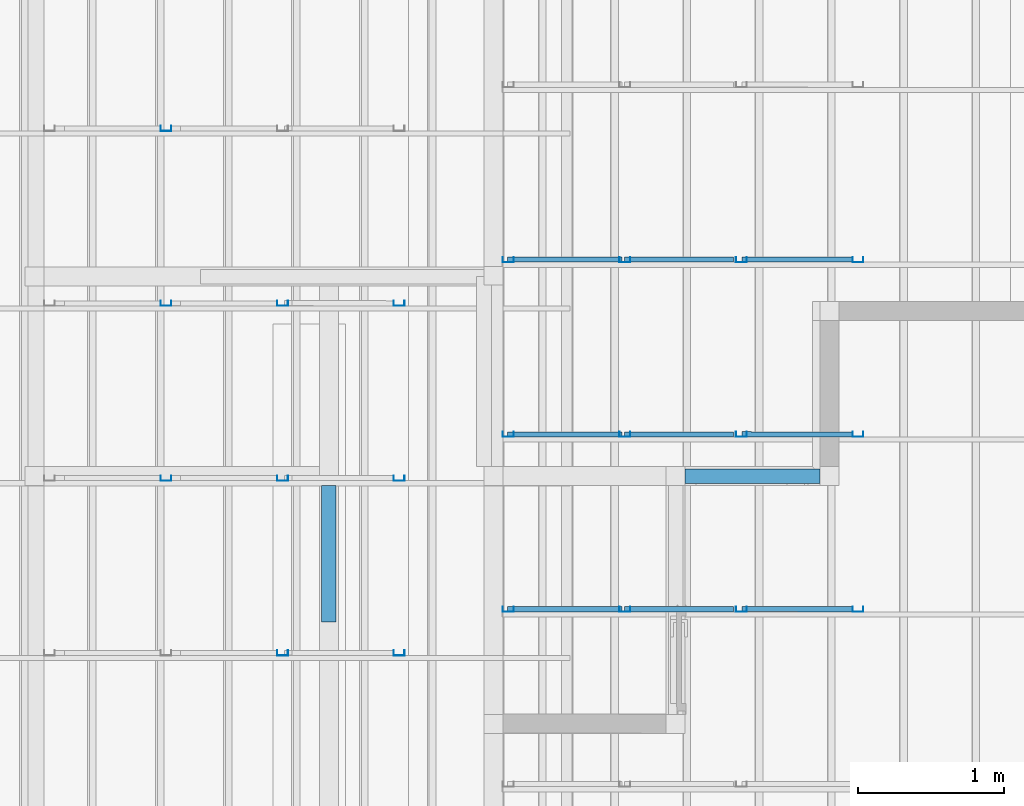
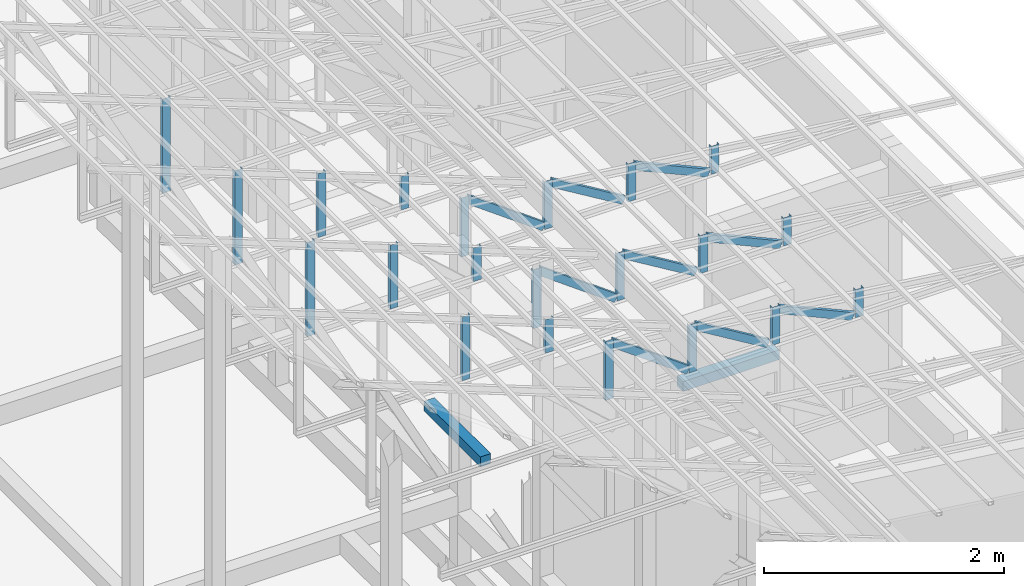
# One storey, part 17 of 22: 30 members, 2 beams, 2 elements without a shape of their own.
"""IFC4 building model written with IfcOpenShell, lengths in millimetres."""

import ifcopenshell
import ifcopenshell.guid

model = None  # the IFC model being written
_history = None  # IfcOwnerHistory: only IFC2X3 demands one
_inside = {}  # id of a spatial element -> (the spatial element, [elements in it])
_under = {}  # id of a project, library or spatial element -> (it, [spatial elements below it])
_declared = {}  # id of a project -> (the project, [libraries it declares])
_typed = {}  # id of a type object -> (the type object, [elements of that type])
_made_of = {}  # id of a material, layer set ... -> (it, [elements and type objects made of it])


def new_model(schema):
    """Start an empty IFC model of exactly this schema.

    Asked for "IFC4X3", IfcOpenShell would pick the latest addendum, in which some entities
    have other attributes; the version numbers below select the first issue.
    IFC2X3 requires an IfcOwnerHistory on every rooted entity: one is made here for all.
    """
    global model, _history
    if schema == "IFC4X3":
        model = ifcopenshell.file(schema_version=(4, 3, 0, 0))
    else:
        model = ifcopenshell.file(schema=schema)
    _inside.clear()
    _under.clear()
    _declared.clear()
    _typed.clear()
    _made_of.clear()
    _history = None
    if model.schema == "IFC2X3":
        org = make("IfcOrganization", Name="unknown")
        user = make(
            "IfcPersonAndOrganization",
            ThePerson=make("IfcPerson", FamilyName="unknown"),
            TheOrganization=org,
        )
        app = make(
            "IfcApplication",
            ApplicationDeveloper=org,
            Version="unknown",
            ApplicationFullName="unknown",
            ApplicationIdentifier="unknown",
        )
        _history = make(
            "IfcOwnerHistory",
            OwningUser=user,
            OwningApplication=app,
            ChangeAction="ADDED",
            CreationDate=0,
        )
    return model


def make(cls, **values):
    """One entity of the class cls with the attributes given. An attribute that is None is left unset."""
    return model.create_entity(
        cls, **{name: value for name, value in values.items() if value is not None}
    )


def entity(cls, *values):
    """Any entity or typed value of the class cls, its attributes in the order of the schema. None: left unset."""
    e = model.create_entity(cls)
    for i, value in enumerate(values):
        if value is not None:
            e[i] = value
    return e


def rooted(cls, **values):
    """An entity with a GlobalId (a new one), such as an element, a storey or a relation."""
    return make(cls, GlobalId=ifcopenshell.guid.new(), OwnerHistory=_history, **values)


def si_unit(unit_type, name, prefix=None):
    """IfcSIUnit, for example si_unit("LENGTHUNIT", "METRE", prefix="MILLI")."""
    return make("IfcSIUnit", UnitType=unit_type, Prefix=prefix, Name=name)


def converted_unit(unit_type, name, factor, base, dimensions=None, offset=None):
    """IfcConversionBasedUnit, such as the inch: factor (a typed value) times the base unit."""
    return make(
        "IfcConversionBasedUnit"
        if offset is None
        else "IfcConversionBasedUnitWithOffset",
        ConversionOffset=offset,
        Dimensions=None
        if dimensions is None
        else entity("IfcDimensionalExponents", *dimensions),
        UnitType=unit_type,
        Name=name,
        ConversionFactor=make(
            "IfcMeasureWithUnit", ValueComponent=factor, UnitComponent=base
        ),
    )


def assignment(units):
    """IfcUnitAssignment: the units of a project."""
    return None if units is None else make("IfcUnitAssignment", Units=units)


def point(xyz):
    """IfcCartesianPoint."""
    return None if xyz is None else make("IfcCartesianPoint", Coordinates=xyz)


def direction(xyz):
    """IfcDirection."""
    return None if xyz is None else make("IfcDirection", DirectionRatios=xyz)


def frame(location, z_axis=None, x_axis=None):
    """IfcAxis2Placement3D, a coordinate frame: its origin and axes. An axis left out is left unset."""
    return make(
        "IfcAxis2Placement3D",
        Location=point(location),
        Axis=direction(z_axis),
        RefDirection=direction(x_axis),
    )


def frame_2d(location, x_axis=None):
    """IfcAxis2Placement2D, a coordinate frame in the plane: its origin and x axis."""
    return make(
        "IfcAxis2Placement2D", Location=point(location), RefDirection=direction(x_axis)
    )


def origin_with_axes():
    """The frame at (0, 0, 0) with the z axis (0, 0, 1) and the x axis (1, 0, 0) written out."""
    return frame((0.0, 0.0, 0.0), z_axis=(0.0, 0.0, 1.0), x_axis=(1.0, 0.0, 0.0))


def origin_2d_with_axis():
    """The frame at (0, 0) in the plane with the x axis (1, 0) written out."""
    return frame_2d((0.0, 0.0), x_axis=(1.0, 0.0))


def place(relative_to, where):
    """IfcLocalPlacement: puts the frame where relative to a parent placement (None: the world)."""
    return make(
        "IfcLocalPlacement", PlacementRelTo=relative_to, RelativePlacement=where
    )


def context(
    kind, dimensions, precision=None, world=None, true_north=None, identifier=None
):
    """IfcGeometricRepresentationContext, for example the 3D "Model" context."""
    return make(
        "IfcGeometricRepresentationContext",
        ContextIdentifier=identifier,
        ContextType=kind,
        CoordinateSpaceDimension=dimensions,
        Precision=precision,
        WorldCoordinateSystem=world,
        TrueNorth=true_north,
    )


def subcontext(parent, identifier, kind, view, scale=None):
    """IfcGeometricRepresentationSubContext, for example "Body" below "Model"."""
    return make(
        "IfcGeometricRepresentationSubContext",
        ContextIdentifier=identifier,
        ContextType=kind,
        ParentContext=parent,
        TargetScale=scale,
        TargetView=view,
    )


def project(units=None, contexts=None):
    """IfcProject with its units and contexts."""
    return rooted(
        "IfcProject",
        Name="project",
        RepresentationContexts=contexts,
        UnitsInContext=assignment(units),
    )


def spatial(cls, under=None, at=None, **own):
    """A site, building, storey or space (cls), placed at a placement, below another one or the project."""
    s = rooted(cls, ObjectPlacement=at, **own)
    if under is not None:
        _under.setdefault(under.id(), (under, []))[1].append(s)
    return s


def profile(cls, at=None, kind="AREA", **sizes):
    """A parametric profile (cls). Its sizes go by their IFC names, for example OverallWidth=200.0."""
    return make(cls, ProfileType=kind, Position=at, **sizes)


def rectangle(**sizes):
    """IfcRectangleProfileDef."""
    return profile("IfcRectangleProfileDef", **sizes)


def c_section(**sizes):
    """IfcCShapeProfileDef."""
    return profile("IfcCShapeProfileDef", **sizes)


def extrude(swept, where, along, depth):
    """IfcExtrudedAreaSolid: the profile swept, set in the frame where, extruded along a direction by depth."""
    return make(
        "IfcExtrudedAreaSolid",
        SweptArea=swept,
        Position=where,
        ExtrudedDirection=direction(along),
        Depth=depth,
    )


def shape(context_of_items, identifier, shape_type, items):
    """IfcShapeRepresentation: the items that make up one representation, for example the "Body"."""
    return make(
        "IfcShapeRepresentation",
        ContextOfItems=context_of_items,
        RepresentationIdentifier=identifier,
        RepresentationType=shape_type,
        Items=items,
    )


def material(Name=None, Category=None):
    """IfcMaterial."""
    return make("IfcMaterial", Name=Name, Category=Category)


def material_profile(
    of_material, cross_section, Name=None, Category=None, Priority=None
):
    """IfcMaterialProfile: a cross section and its material."""
    return make(
        "IfcMaterialProfile",
        Name=Name,
        Material=of_material,
        Profile=cross_section,
        Priority=Priority,
        Category=Category,
    )


def profile_set(profiles, Name=None, composite=None):
    """IfcMaterialProfileSet."""
    return make(
        "IfcMaterialProfileSet",
        Name=Name,
        MaterialProfiles=profiles,
        CompositeProfile=composite,
    )


def profile_usage(for_profile_set, cardinal=None, extent=None):
    """IfcMaterialProfileSetUsage: how a profile set lies along its element."""
    return make(
        "IfcMaterialProfileSetUsage",
        ForProfileSet=for_profile_set,
        CardinalPoint=cardinal,
        ReferenceExtent=extent,
    )


def made_of(thing, what):
    """Note that an element or type object is made of a material, layer set ...; save() writes the relation."""
    if what is not None:
        _made_of.setdefault(what.id(), (what, []))[1].append(thing)
    return thing


def type_object(cls, material=None, **own):
    """A type object (cls), such as IfcWallType, which elements share."""
    return made_of(rooted(cls, **own), material)


def element(
    cls,
    number,
    at=None,
    inside=None,
    cuts=None,
    type_object=None,
    material=None,
    context=None,
    identifier="Body",
    shape_type=None,
    held_by="IfcProductDefinitionShape",
    body=None,
    shapes=None,
    **own,
):
    """One element of the class cls, such as IfcWall. Its Tag is "e" and its number.

    at: its placement. inside: the storey or other place that contains it. cuts: it is an
    opening in that element (IfcRelVoidsElement). A single representation is given by context,
    identifier, shape_type and body (its items); several are given by shapes. held_by: the class
    of the entity that holds the representations. save() writes the other relations.
    """
    e = rooted(cls, Tag="e%d" % number, ObjectPlacement=at, **own)
    if body is not None:
        shapes = [shape(context, identifier, shape_type, body)]
    if shapes is not None:
        e.Representation = make(held_by, Representations=shapes)
    if inside is not None:
        _inside.setdefault(inside.id(), (inside, []))[1].append(e)
    if cuts is not None:
        rooted(
            "IfcRelVoidsElement", RelatingBuildingElement=cuts, RelatedOpeningElement=e
        )
    if type_object is not None:
        _typed.setdefault(type_object.id(), (type_object, []))[1].append(e)
    return made_of(e, material)


def aggregate(whole, parts):
    """IfcRelAggregates: a whole, such as a stair, and the parts it consists of."""
    return rooted("IfcRelAggregates", RelatingObject=whole, RelatedObjects=parts)


def save(model, path):
    """Write the relations noted so far, then the file.

    IfcRelAggregates (storeys below a building ...), IfcRelContainedInSpatialStructure (elements
    in a storey), IfcRelDefinesByType, IfcRelAssociatesMaterial and IfcRelDeclares: one each for
    every whole, place, type object, material and project.
    """
    for whole, parts in _under.values():
        aggregate(whole, parts)
    for where, things in _inside.values():
        rooted(
            "IfcRelContainedInSpatialStructure",
            RelatedElements=things,
            RelatingStructure=where,
        )
    for kind, things in _typed.values():
        rooted("IfcRelDefinesByType", RelatedObjects=things, RelatingType=kind)
    for what, things in _made_of.values():
        rooted("IfcRelAssociatesMaterial", RelatedObjects=things, RelatingMaterial=what)
    for by, libraries in _declared.values():
        rooted("IfcRelDeclares", RelatingContext=by, RelatedDefinitions=libraries)
    model.write(path)


model = new_model("IFC4")

# Units and contexts
model_context = context("Model", 3, precision=1e-05, world=origin_with_axes())
plan_context = context("Plan", 2, precision=1e-05, world=origin_2d_with_axis())
body_context = subcontext(model_context, "Body", "Model", "MODEL_VIEW")
ifc_project = project(units=[si_unit("VOLUMEUNIT", "CUBIC_METRE"), si_unit("LENGTHUNIT", "METRE", prefix="MILLI"), si_unit("AREAUNIT", "SQUARE_METRE"), converted_unit("PLANEANGLEUNIT", "degree", entity("IfcReal", 0.0174532925199433), si_unit("PLANEANGLEUNIT", "RADIAN"), dimensions=[0, 0, 0, 0, 0, 0, 0])], contexts=[model_context, plan_context])

# Site, building, storey
site_placement = place(None, origin_with_axes())
site = spatial("IfcSite", under=ifc_project, at=site_placement)
building_placement = place(site_placement, origin_with_axes())
building = spatial("IfcBuilding", under=site, at=building_placement, Name="2")
storey_placement = place(building_placement, frame((0.0, 0.0, 200.000002980232), z_axis=(0.0, 0.0, 1.0), x_axis=(1.0, 0.0, 0.0)))
storey = spatial("IfcBuildingStorey", under=building, at=storey_placement)

# Assembly, members
assembly_1_placement = place(storey_placement, frame((-1561.45393848419, 6600.0657081604, 3019.63977515697), z_axis=(0.0, 0.0, 1.0), x_axis=(1.0, 0.0, 0.0)))
assembly_1 = element("IfcElementAssembly", 1, at=assembly_1_placement, inside=storey, Name="K1")
ifc_material_1 = material(Name="STEEL")
ifc_material_profile_1 = material_profile(ifc_material_1, c_section(Depth=75.0, Width=35.0, WallThickness=1.0, Girth=1.0, kind="CURVE"))
ifc_profile_set_1 = profile_set([ifc_material_profile_1])
ifc_profile_usage_1 = profile_usage(ifc_profile_set_1, cardinal=9)
member_type = type_object("IfcMemberType", Name="C75", PredefinedType="CHORD", material=ifc_profile_set_1)
member_1_placement = place(assembly_1_placement, frame((100.488781929016, 2398.93293380737, 276.402950286865), z_axis=(-8.7422719730052e-08, 3.25841369885875e-07, -0.999999999999943), x_axis=(1.62920684942936e-07, 0.999999999999934, 3.25841369885871e-07)))
member_1 = element("IfcMember", 2, at=member_1_placement, type_object=member_type, material=ifc_profile_usage_1, Name="Member", context=body_context, shape_type="SweptSolid", body=[
    extrude(c_section(Depth=75.0, Width=35.0, WallThickness=1.0, Girth=1.0, kind="CURVE"), frame((17.5, -37.5, 0.0), z_axis=(0.0, 0.0, 1.0), x_axis=(1.0, 0.0, 0.0)), (0.0, 0.0, 1.0), 285.419225275215),
])
ifc_profile_usage_2 = profile_usage(ifc_profile_set_1, cardinal=9)
member_2_placement = place(assembly_1_placement, frame((-1499.51112270355, 2398.93293380737, 479.381561279297), z_axis=(0.855801528545197, -4.23314648434558e-08, -0.517304304775924), x_axis=(7.5497901264043e-08, 0.999999999999996, 4.30689546249139e-08)))
member_2 = element("IfcMember", 3, at=member_2_placement, type_object=member_type, material=ifc_profile_usage_2, Name="Member", context=body_context, shape_type="SweptSolid", body=[
    extrude(c_section(Depth=75.0, Width=35.0, WallThickness=1.0, Girth=1.0, kind="CURVE"), frame((17.5, -37.5, 0.0), z_axis=(0.0, 0.0, 1.0), x_axis=(1.0, 0.0, 0.0)), (0.0, 0.0, 1.0), 826.976096113964),
])
ifc_profile_usage_3 = profile_usage(ifc_profile_set_1, cardinal=9)
member_3_placement = place(assembly_1_placement, frame((-1499.51112270355, 2398.93293380737, 479.381561279297), z_axis=(-8.7422719730052e-08, 3.25841369885875e-07, -0.999999999999943), x_axis=(1.62920684942936e-07, 0.999999999999934, 3.25841369885871e-07)))
member_3 = element("IfcMember", 4, at=member_3_placement, type_object=member_type, material=ifc_profile_usage_3, Name="Member", context=body_context, shape_type="SweptSolid", body=[
    extrude(c_section(Depth=75.0, Width=35.0, WallThickness=1.0, Girth=1.0, kind="CURVE"), frame((17.5, -37.5, 0.0), z_axis=(0.0, 0.0, 1.0), x_axis=(1.0, 0.0, 0.0)), (0.0, 0.0, 1.0), 488.397843745656),
])
ifc_profile_usage_4 = profile_usage(ifc_profile_set_1, cardinal=9)
member_4_placement = place(assembly_1_placement, frame((-2299.51107501984, 2398.93293380737, 592.46301651001), z_axis=(0.807471586940316, -1.26964538798404e-07, -0.589906464012789), x_axis=(7.54979012640426e-08, 0.999999999999991, -1.1188575399501e-07)))
member_4 = element("IfcMember", 5, at=member_4_placement, type_object=member_type, material=ifc_profile_usage_4, Name="Member", context=body_context, shape_type="SweptSolid", body=[
    extrude(c_section(Depth=75.0, Width=35.0, WallThickness=1.0, Girth=1.0, kind="CURVE"), frame((17.5, -37.5, 0.0), z_axis=(0.0, 0.0, 1.0), x_axis=(1.0, 0.0, 0.0)), (0.0, 0.0, 1.0), 921.685377112707),
])
ifc_profile_usage_5 = profile_usage(ifc_profile_set_1, cardinal=9)
member_5_placement = place(assembly_1_placement, frame((-702.355027198792, 2399.93238449097, 368.052959442139), z_axis=(0.912206913056706, -0.00121979383816088, -0.409728031594797), x_axis=(0.00137145876901944, 0.999999056639273, 7.62981516029096e-05)))
member_5 = element("IfcMember", 6, at=member_5_placement, type_object=member_type, material=ifc_profile_usage_5, Name="Member", context=body_context, shape_type="SweptSolid", body=[
    extrude(c_section(Depth=75.0, Width=35.0, WallThickness=1.0, Girth=1.0, kind="CURVE"), frame((17.5, -37.5, 0.0), z_axis=(0.0, 0.0, 1.0), x_axis=(1.0, 0.0, 0.0)), (0.0, 0.0, 1.0), 791.494517196627),
])
ifc_profile_usage_6 = profile_usage(ifc_profile_set_1, cardinal=9)
member_6_placement = place(assembly_1_placement, frame((-2299.51107501984, 2398.93293380737, 592.46301651001), z_axis=(-8.7422719730052e-08, 3.25841369885875e-07, -0.999999999999943), x_axis=(1.62920684942936e-07, 0.999999999999934, 3.25841369885871e-07)))
member_6 = element("IfcMember", 7, at=member_6_placement, type_object=member_type, material=ifc_profile_usage_6, Name="Member", context=body_context, shape_type="SweptSolid", body=[
    extrude(c_section(Depth=75.0, Width=35.0, WallThickness=1.0, Girth=1.0, kind="CURVE"), frame((17.5, -37.5, 0.0), z_axis=(0.0, 0.0, 1.0), x_axis=(1.0, 0.0, 0.0)), (0.0, 0.0, 1.0), 601.479041515268),
])
ifc_profile_usage_7 = profile_usage(ifc_profile_set_1, cardinal=9)
member_7_placement = place(assembly_1_placement, frame((-699.511170387268, 2398.93293380737, 377.824306488037), z_axis=(-8.7422719730052e-08, 3.25841369885875e-07, -0.999999999999943), x_axis=(1.62920684942936e-07, 0.999999999999934, 3.25841369885871e-07)))
member_7 = element("IfcMember", 8, at=member_7_placement, type_object=member_type, material=ifc_profile_usage_7, Name="Member", context=body_context, shape_type="SweptSolid", body=[
    extrude(c_section(Depth=75.0, Width=35.0, WallThickness=1.0, Girth=1.0, kind="CURVE"), frame((17.5, -37.5, 0.0), z_axis=(0.0, 0.0, 1.0), x_axis=(1.0, 0.0, 0.0)), (0.0, 0.0, 1.0), 386.840589191612),
])
ifc_profile_usage_8 = profile_usage(ifc_profile_set_1, cardinal=9)
member_8_placement = place(assembly_1_placement, frame((-1499.51112270355, 3598.93274307251, 479.381561279297), z_axis=(0.855801528545197, -4.23314648434558e-08, -0.517304304775924), x_axis=(7.5497901264043e-08, 0.999999999999996, 4.30689546249139e-08)))
member_8 = element("IfcMember", 9, at=member_8_placement, type_object=member_type, material=ifc_profile_usage_8, Name="Member", context=body_context, shape_type="SweptSolid", body=[
    extrude(c_section(Depth=75.0, Width=35.0, WallThickness=1.0, Girth=1.0, kind="CURVE"), frame((17.5, -37.5, 0.0), z_axis=(0.0, 0.0, 1.0), x_axis=(1.0, 0.0, 0.0)), (0.0, 0.0, 1.0), 826.976096113964),
])
ifc_profile_usage_9 = profile_usage(ifc_profile_set_1, cardinal=9)
member_9_placement = place(assembly_1_placement, frame((-1499.51112270355, 3598.93274307251, 479.381561279297), z_axis=(-8.7422719730052e-08, 3.25841369885875e-07, -0.999999999999943), x_axis=(1.62920684942936e-07, 0.999999999999934, 3.25841369885871e-07)))
member_9 = element("IfcMember", 10, at=member_9_placement, type_object=member_type, material=ifc_profile_usage_9, Name="Member", context=body_context, shape_type="SweptSolid", body=[
    extrude(c_section(Depth=75.0, Width=35.0, WallThickness=1.0, Girth=1.0, kind="CURVE"), frame((17.5, -37.5, 0.0), z_axis=(0.0, 0.0, 1.0), x_axis=(1.0, 0.0, 0.0)), (0.0, 0.0, 1.0), 488.397843745656),
])
ifc_profile_usage_10 = profile_usage(ifc_profile_set_1, cardinal=9)
member_10_placement = place(assembly_1_placement, frame((-702.355027198792, 3599.9321937561, 368.052959442139), z_axis=(0.912206913056706, -0.00121979383816088, -0.409728031594797), x_axis=(0.00137145876901944, 0.999999056639273, 7.62981516029096e-05)))
member_10 = element("IfcMember", 11, at=member_10_placement, type_object=member_type, material=ifc_profile_usage_10, Name="Member", context=body_context, shape_type="SweptSolid", body=[
    extrude(c_section(Depth=75.0, Width=35.0, WallThickness=1.0, Girth=1.0, kind="CURVE"), frame((17.5, -37.5, 0.0), z_axis=(0.0, 0.0, 1.0), x_axis=(1.0, 0.0, 0.0)), (0.0, 0.0, 1.0), 791.494517196627),
])
ifc_profile_usage_11 = profile_usage(ifc_profile_set_1, cardinal=9)
member_11_placement = place(assembly_1_placement, frame((100.488781929016, 3598.93274307251, 276.402950286865), z_axis=(-8.7422719730052e-08, 3.25841369885875e-07, -0.999999999999943), x_axis=(1.62920684942936e-07, 0.999999999999934, 3.25841369885871e-07)))
member_11 = element("IfcMember", 12, at=member_11_placement, type_object=member_type, material=ifc_profile_usage_11, Name="Member", context=body_context, shape_type="SweptSolid", body=[
    extrude(c_section(Depth=75.0, Width=35.0, WallThickness=1.0, Girth=1.0, kind="CURVE"), frame((17.5, -37.5, 0.0), z_axis=(0.0, 0.0, 1.0), x_axis=(1.0, 0.0, 0.0)), (0.0, 0.0, 1.0), 285.419225275215),
])
ifc_profile_usage_12 = profile_usage(ifc_profile_set_1, cardinal=9)
member_12_placement = place(assembly_1_placement, frame((-2299.51107501984, 3598.93274307251, 592.46301651001), z_axis=(0.807471586940316, -1.26964538798404e-07, -0.589906464012789), x_axis=(7.54979012640426e-08, 0.999999999999991, -1.1188575399501e-07)))
member_12 = element("IfcMember", 13, at=member_12_placement, type_object=member_type, material=ifc_profile_usage_12, Name="Member", context=body_context, shape_type="SweptSolid", body=[
    extrude(c_section(Depth=75.0, Width=35.0, WallThickness=1.0, Girth=1.0, kind="CURVE"), frame((17.5, -37.5, 0.0), z_axis=(0.0, 0.0, 1.0), x_axis=(1.0, 0.0, 0.0)), (0.0, 0.0, 1.0), 921.685377112707),
])
ifc_profile_usage_13 = profile_usage(ifc_profile_set_1, cardinal=9)
member_13_placement = place(assembly_1_placement, frame((-2299.51107501984, 3598.93274307251, 592.46301651001), z_axis=(-8.7422719730052e-08, 3.25841369885875e-07, -0.999999999999943), x_axis=(1.62920684942936e-07, 0.999999999999934, 3.25841369885871e-07)))
member_13 = element("IfcMember", 14, at=member_13_placement, type_object=member_type, material=ifc_profile_usage_13, Name="Member", context=body_context, shape_type="SweptSolid", body=[
    extrude(c_section(Depth=75.0, Width=35.0, WallThickness=1.0, Girth=1.0, kind="CURVE"), frame((17.5, -37.5, 0.0), z_axis=(0.0, 0.0, 1.0), x_axis=(1.0, 0.0, 0.0)), (0.0, 0.0, 1.0), 601.479041515268),
])
ifc_profile_usage_14 = profile_usage(ifc_profile_set_1, cardinal=9)
member_14_placement = place(assembly_1_placement, frame((-699.511170387268, 3598.93274307251, 377.824306488037), z_axis=(-8.7422719730052e-08, 3.25841369885875e-07, -0.999999999999943), x_axis=(1.62920684942936e-07, 0.999999999999934, 3.25841369885871e-07)))
member_14 = element("IfcMember", 15, at=member_14_placement, type_object=member_type, material=ifc_profile_usage_14, Name="Member", context=body_context, shape_type="SweptSolid", body=[
    extrude(c_section(Depth=75.0, Width=35.0, WallThickness=1.0, Girth=1.0, kind="CURVE"), frame((17.5, -37.5, 0.0), z_axis=(0.0, 0.0, 1.0), x_axis=(1.0, 0.0, 0.0)), (0.0, 0.0, 1.0), 386.840589191612),
])
ifc_profile_usage_15 = profile_usage(ifc_profile_set_1, cardinal=9)
member_15_placement = place(assembly_1_placement, frame((-702.355027198792, 4799.93200302124, 368.052959442139), z_axis=(0.912206913056706, -0.00121979383816088, -0.409728031594797), x_axis=(0.00137145876901944, 0.999999056639273, 7.62981516029096e-05)))
member_15 = element("IfcMember", 16, at=member_15_placement, type_object=member_type, material=ifc_profile_usage_15, Name="Member", context=body_context, shape_type="SweptSolid", body=[
    extrude(c_section(Depth=75.0, Width=35.0, WallThickness=1.0, Girth=1.0, kind="CURVE"), frame((17.5, -37.5, 0.0), z_axis=(0.0, 0.0, 1.0), x_axis=(1.0, 0.0, 0.0)), (0.0, 0.0, 1.0), 791.494517196627),
])
ifc_profile_usage_16 = profile_usage(ifc_profile_set_1, cardinal=9)
member_16_placement = place(assembly_1_placement, frame((-1499.51112270355, 4798.93255233765, 479.381561279297), z_axis=(-8.7422719730052e-08, 3.25841369885875e-07, -0.999999999999943), x_axis=(1.62920684942936e-07, 0.999999999999934, 3.25841369885871e-07)))
member_16 = element("IfcMember", 17, at=member_16_placement, type_object=member_type, material=ifc_profile_usage_16, Name="Member", context=body_context, shape_type="SweptSolid", body=[
    extrude(c_section(Depth=75.0, Width=35.0, WallThickness=1.0, Girth=1.0, kind="CURVE"), frame((17.5, -37.5, 0.0), z_axis=(0.0, 0.0, 1.0), x_axis=(1.0, 0.0, 0.0)), (0.0, 0.0, 1.0), 488.397843745656),
])
ifc_profile_usage_17 = profile_usage(ifc_profile_set_1, cardinal=9)
member_17_placement = place(assembly_1_placement, frame((-2299.51107501984, 4798.93255233765, 592.46301651001), z_axis=(0.807471586940316, -1.26964538798404e-07, -0.589906464012789), x_axis=(7.54979012640426e-08, 0.999999999999991, -1.1188575399501e-07)))
member_17 = element("IfcMember", 18, at=member_17_placement, type_object=member_type, material=ifc_profile_usage_17, Name="Member", context=body_context, shape_type="SweptSolid", body=[
    extrude(c_section(Depth=75.0, Width=35.0, WallThickness=1.0, Girth=1.0, kind="CURVE"), frame((17.5, -37.5, 0.0), z_axis=(0.0, 0.0, 1.0), x_axis=(1.0, 0.0, 0.0)), (0.0, 0.0, 1.0), 921.685377112707),
])
ifc_profile_usage_18 = profile_usage(ifc_profile_set_1, cardinal=9)
member_18_placement = place(assembly_1_placement, frame((-2299.51107501984, 4798.93255233765, 592.46301651001), z_axis=(-8.7422719730052e-08, 3.25841369885875e-07, -0.999999999999943), x_axis=(1.62920684942936e-07, 0.999999999999934, 3.25841369885871e-07)))
member_18 = element("IfcMember", 19, at=member_18_placement, type_object=member_type, material=ifc_profile_usage_18, Name="Member", context=body_context, shape_type="SweptSolid", body=[
    extrude(c_section(Depth=75.0, Width=35.0, WallThickness=1.0, Girth=1.0, kind="CURVE"), frame((17.5, -37.5, 0.0), z_axis=(0.0, 0.0, 1.0), x_axis=(1.0, 0.0, 0.0)), (0.0, 0.0, 1.0), 601.479041515268),
])
ifc_profile_usage_19 = profile_usage(ifc_profile_set_1, cardinal=9)
member_19_placement = place(assembly_1_placement, frame((-1499.51112270355, 4798.93255233765, 479.381561279297), z_axis=(0.855801528545197, -4.23314648434558e-08, -0.517304304775924), x_axis=(7.5497901264043e-08, 0.999999999999996, 4.30689546249139e-08)))
member_19 = element("IfcMember", 20, at=member_19_placement, type_object=member_type, material=ifc_profile_usage_19, Name="Member", context=body_context, shape_type="SweptSolid", body=[
    extrude(c_section(Depth=75.0, Width=35.0, WallThickness=1.0, Girth=1.0, kind="CURVE"), frame((17.5, -37.5, 0.0), z_axis=(0.0, 0.0, 1.0), x_axis=(1.0, 0.0, 0.0)), (0.0, 0.0, 1.0), 826.976096113964),
])
ifc_profile_usage_20 = profile_usage(ifc_profile_set_1, cardinal=9)
member_20_placement = place(assembly_1_placement, frame((100.488781929016, 4798.93255233765, 276.402950286865), z_axis=(-8.7422719730052e-08, 3.25841369885875e-07, -0.999999999999943), x_axis=(1.62920684942936e-07, 0.999999999999934, 3.25841369885871e-07)))
member_20 = element("IfcMember", 21, at=member_20_placement, type_object=member_type, material=ifc_profile_usage_20, Name="Member", context=body_context, shape_type="SweptSolid", body=[
    extrude(c_section(Depth=75.0, Width=35.0, WallThickness=1.0, Girth=1.0, kind="CURVE"), frame((17.5, -37.5, 0.0), z_axis=(0.0, 0.0, 1.0), x_axis=(1.0, 0.0, 0.0)), (0.0, 0.0, 1.0), 285.419225275215),
])
ifc_profile_usage_21 = profile_usage(ifc_profile_set_1, cardinal=9)
member_21_placement = place(assembly_1_placement, frame((-699.511170387268, 4798.93255233765, 377.824306488037), z_axis=(-8.7422719730052e-08, 3.25841369885875e-07, -0.999999999999943), x_axis=(1.62920684942936e-07, 0.999999999999934, 3.25841369885871e-07)))
member_21 = element("IfcMember", 22, at=member_21_placement, type_object=member_type, material=ifc_profile_usage_21, Name="Member", context=body_context, shape_type="SweptSolid", body=[
    extrude(c_section(Depth=75.0, Width=35.0, WallThickness=1.0, Girth=1.0, kind="CURVE"), frame((17.5, -37.5, 0.0), z_axis=(0.0, 0.0, 1.0), x_axis=(1.0, 0.0, 0.0)), (0.0, 0.0, 1.0), 386.840589191612),
])
aggregate(assembly_1, [member_1, member_2, member_3, member_4, member_5, member_6, member_7, member_8, member_9, member_10, member_11, member_12, member_13, member_14, member_15, member_16, member_17, member_18, member_19, member_20, member_21])

assembly_2_placement = place(storey_placement, frame((-3938.51041793823, 5099.00283813477, 3935.3459328413), z_axis=(0.0, 0.0, 1.0), x_axis=(1.0, 0.0, 0.0)))
assembly_2 = element("IfcElementAssembly", 23, at=assembly_2_placement, inside=storey, Name="2")
ifc_profile_usage_22 = profile_usage(ifc_profile_set_1, cardinal=1)
member_22_placement = place(assembly_2_placement, frame((-1546.51069641113, 3634.9983215332, 648.419380187988), z_axis=(-8.74227410463377e-08, -1.50995830949794e-07, -0.999999999999985), x_axis=(-3.13916473260159e-07, 0.999999999999939, -1.50995802528077e-07)))
member_22 = element("IfcMember", 24, at=member_22_placement, type_object=member_type, material=ifc_profile_usage_22, Name="Member", context=body_context, shape_type="SweptSolid", body=[
    extrude(c_section(Depth=75.0, Width=35.0, WallThickness=1.0, Girth=1.0, kind="CURVE"), frame((-17.5, 37.5, 0.0), z_axis=(0.0, 0.0, 1.0), x_axis=(1.0, 0.0, 0.0)), (0.0, 0.0, 1.0), 649.773129888493),
])
ifc_profile_usage_23 = profile_usage(ifc_profile_set_1, cardinal=1)
member_23_placement = place(assembly_2_placement, frame((-746.51050567627, 3634.9983215332, 339.939117431641), z_axis=(-8.74227410463377e-08, -1.50995830949794e-07, -0.999999999999985), x_axis=(-3.13916473260159e-07, 0.999999999999939, -1.50995802528077e-07)))
member_23 = element("IfcMember", 25, at=member_23_placement, type_object=member_type, material=ifc_profile_usage_23, Name="Member", context=body_context, shape_type="SweptSolid", body=[
    extrude(c_section(Depth=75.0, Width=35.0, WallThickness=1.0, Girth=1.0, kind="CURVE"), frame((-17.5, 37.5, 0.0), z_axis=(0.0, 0.0, 1.0), x_axis=(1.0, 0.0, 0.0)), (0.0, 0.0, 1.0), 341.292854350017),
])
ifc_profile_usage_24 = profile_usage(ifc_profile_set_1, cardinal=1)
member_24_placement = place(assembly_2_placement, frame((-2346.510887146, 4834.99813079834, 957.056522369385), z_axis=(-8.74227410463377e-08, -1.50995830949794e-07, -0.999999999999985), x_axis=(-3.13916473260159e-07, 0.999999999999939, -1.50995802528077e-07)))
member_24 = element("IfcMember", 26, at=member_24_placement, type_object=member_type, material=ifc_profile_usage_24, Name="Member", context=body_context, shape_type="SweptSolid", body=[
    extrude(c_section(Depth=75.0, Width=35.0, WallThickness=1.0, Girth=1.0, kind="CURVE"), frame((-17.5, 37.5, 0.0), z_axis=(0.0, 0.0, 1.0), x_axis=(1.0, 0.0, 0.0)), (0.0, 0.0, 1.0), 958.410273794281),
])
ifc_profile_usage_25 = profile_usage(ifc_profile_set_1, cardinal=1)
member_25_placement = place(assembly_2_placement, frame((-1546.51069641113, 4834.99813079834, 648.419380187988), z_axis=(-8.74227410463377e-08, -1.50995830949794e-07, -0.999999999999985), x_axis=(-3.13916473260159e-07, 0.999999999999939, -1.50995802528077e-07)))
member_25 = element("IfcMember", 27, at=member_25_placement, type_object=member_type, material=ifc_profile_usage_25, Name="Member", context=body_context, shape_type="SweptSolid", body=[
    extrude(c_section(Depth=75.0, Width=35.0, WallThickness=1.0, Girth=1.0, kind="CURVE"), frame((-17.5, 37.5, 0.0), z_axis=(0.0, 0.0, 1.0), x_axis=(1.0, 0.0, 0.0)), (0.0, 0.0, 1.0), 649.773129888493),
])
ifc_profile_usage_26 = profile_usage(ifc_profile_set_1, cardinal=1)
member_26_placement = place(assembly_2_placement, frame((-746.51050567627, 4834.99813079834, 339.939117431641), z_axis=(-8.74227410463377e-08, -1.50995830949794e-07, -0.999999999999985), x_axis=(-3.13916473260159e-07, 0.999999999999939, -1.50995802528077e-07)))
member_26 = element("IfcMember", 28, at=member_26_placement, type_object=member_type, material=ifc_profile_usage_26, Name="Member", context=body_context, shape_type="SweptSolid", body=[
    extrude(c_section(Depth=75.0, Width=35.0, WallThickness=1.0, Girth=1.0, kind="CURVE"), frame((-17.5, 37.5, 0.0), z_axis=(0.0, 0.0, 1.0), x_axis=(1.0, 0.0, 0.0)), (0.0, 0.0, 1.0), 341.292854350017),
])
ifc_profile_usage_27 = profile_usage(ifc_profile_set_1, cardinal=1)
member_27_placement = place(assembly_2_placement, frame((-1546.51069641113, 6034.99794006348, 648.419380187988), z_axis=(-8.74227410463377e-08, -1.50995830949794e-07, -0.999999999999985), x_axis=(-3.13916473260159e-07, 0.999999999999939, -1.50995802528077e-07)))
member_27 = element("IfcMember", 29, at=member_27_placement, type_object=member_type, material=ifc_profile_usage_27, Name="Member", context=body_context, shape_type="SweptSolid", body=[
    extrude(c_section(Depth=75.0, Width=35.0, WallThickness=1.0, Girth=1.0, kind="CURVE"), frame((-17.5, 37.5, 0.0), z_axis=(0.0, 0.0, 1.0), x_axis=(1.0, 0.0, 0.0)), (0.0, 0.0, 1.0), 649.773129888493),
])
ifc_profile_usage_28 = profile_usage(ifc_profile_set_1, cardinal=1)
member_28_placement = place(assembly_2_placement, frame((-2346.510887146, 6034.99794006348, 957.056522369385), z_axis=(-8.74227410463377e-08, -1.50995830949794e-07, -0.999999999999985), x_axis=(-3.13916473260159e-07, 0.999999999999939, -1.50995802528077e-07)))
member_28 = element("IfcMember", 30, at=member_28_placement, type_object=member_type, material=ifc_profile_usage_28, Name="Member", context=body_context, shape_type="SweptSolid", body=[
    extrude(c_section(Depth=75.0, Width=35.0, WallThickness=1.0, Girth=1.0, kind="CURVE"), frame((-17.5, 37.5, 0.0), z_axis=(0.0, 0.0, 1.0), x_axis=(1.0, 0.0, 0.0)), (0.0, 0.0, 1.0), 958.410273794281),
])
ifc_profile_usage_29 = profile_usage(ifc_profile_set_1, cardinal=1)
member_29_placement = place(assembly_2_placement, frame((-746.51050567627, 6034.99794006348, 339.939117431641), z_axis=(-8.74227410463377e-08, -1.50995830949794e-07, -0.999999999999985), x_axis=(-3.13916473260159e-07, 0.999999999999939, -1.50995802528077e-07)))
member_29 = element("IfcMember", 31, at=member_29_placement, type_object=member_type, material=ifc_profile_usage_29, Name="Member", context=body_context, shape_type="SweptSolid", body=[
    extrude(c_section(Depth=75.0, Width=35.0, WallThickness=1.0, Girth=1.0, kind="CURVE"), frame((-17.5, 37.5, 0.0), z_axis=(0.0, 0.0, 1.0), x_axis=(1.0, 0.0, 0.0)), (0.0, 0.0, 1.0), 341.292854350017),
])
ifc_profile_usage_30 = profile_usage(ifc_profile_set_1, cardinal=1)
member_30_placement = place(assembly_2_placement, frame((-2346.510887146, 7234.99774932861, 957.056522369385), z_axis=(-8.74227410463377e-08, -1.50995830949794e-07, -0.999999999999985), x_axis=(-3.13916473260159e-07, 0.999999999999939, -1.50995802528077e-07)))
member_30 = element("IfcMember", 32, at=member_30_placement, type_object=member_type, material=ifc_profile_usage_30, Name="Member", context=body_context, shape_type="SweptSolid", body=[
    extrude(c_section(Depth=75.0, Width=35.0, WallThickness=1.0, Girth=1.0, kind="CURVE"), frame((-17.5, 37.5, 0.0), z_axis=(0.0, 0.0, 1.0), x_axis=(1.0, 0.0, 0.0)), (0.0, 0.0, 1.0), 958.410273794281),
])
aggregate(assembly_2, [member_22, member_23, member_24, member_25, member_26, member_27, member_28, member_29, member_30])

# Beams
ifc_material_2 = material(Name="Concrete")
ifc_material_profile_2 = material_profile(ifc_material_2, rectangle(XDim=100.0, YDim=100.0))
ifc_profile_set_2 = profile_set([ifc_material_profile_2])
ifc_profile_usage_31 = profile_usage(ifc_profile_set_2, cardinal=2)
beam_type = type_object("IfcBeamType", PredefinedType="BEAM", material=ifc_profile_set_2)
beam_1_placement = place(storey_placement, frame((-5129.99534606934, 8929.98218536377, 2815.0051087141), z_axis=(3.89414367418746e-07, 0.999999999999875, 3.13916473260139e-07), x_axis=(-0.999999999999924, 3.89414367418765e-07, -7.40532613008271e-09)))
element("IfcBeam", 33, at=beam_1_placement, inside=storey, type_object=beam_type, material=ifc_profile_usage_31, Name="Beam", PredefinedType="BEAM", context=body_context, shape_type="SweptSolid", body=[
    extrude(rectangle(XDim=100.0, YDim=100.0), frame((0.0, 50.0, 0.0), z_axis=(0.0, 0.0, 1.0), x_axis=(1.0, 0.0, 0.0)), (0.0, 0.0, 1.0), 937.162402085177),
])
ifc_profile_usage_32 = profile_usage(ifc_profile_set_2)
beam_2_placement = place(storey_placement, frame((-2684.9946975708, 9930.00030517578, 2180.00034987926), z_axis=(0.999999999999825, 5.20548553595199e-07, -2.82129974493678e-07), x_axis=(-5.2054855359522e-07, 0.999999999999865, 5.68434188608003e-14)))
element("IfcBeam", 34, at=beam_2_placement, inside=storey, type_object=beam_type, material=ifc_profile_usage_32, Name="Beam", PredefinedType="BEAM", context=body_context, shape_type="SweptSolid", body=[
    extrude(rectangle(XDim=100.0, YDim=100.0), origin_with_axes(), (0.0, 0.0, 1.0), 924.99447640549),
])

save(model, "model.ifc")
